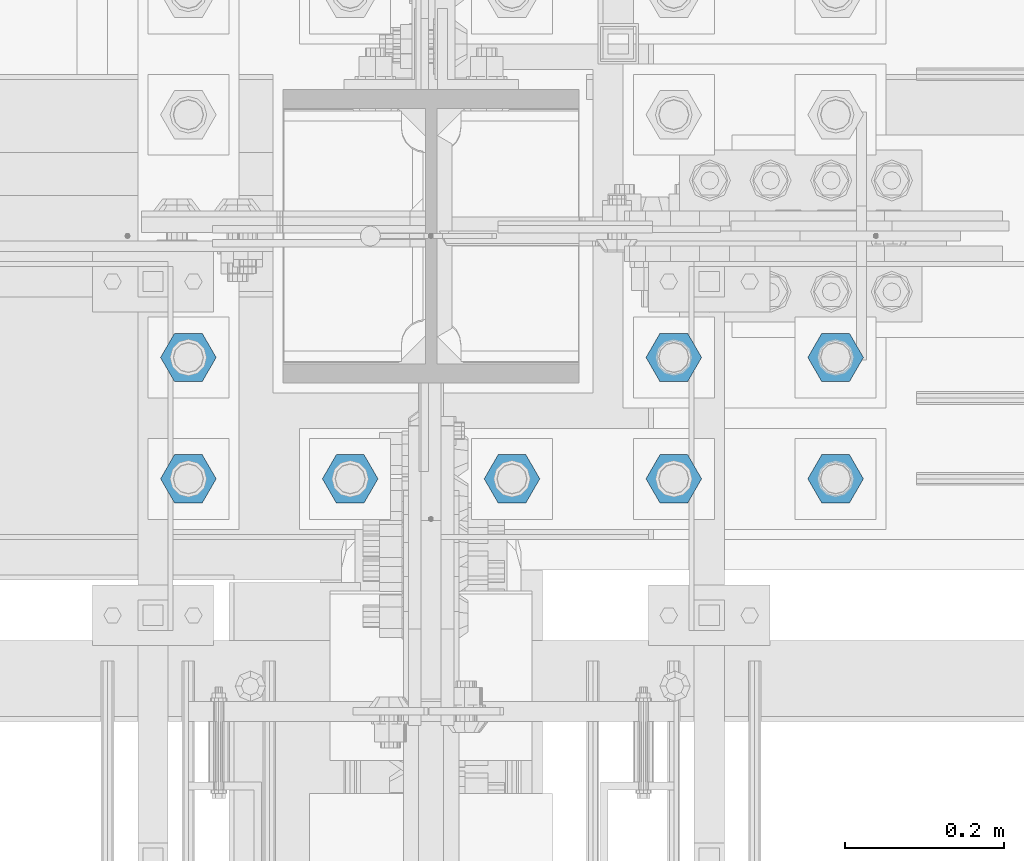
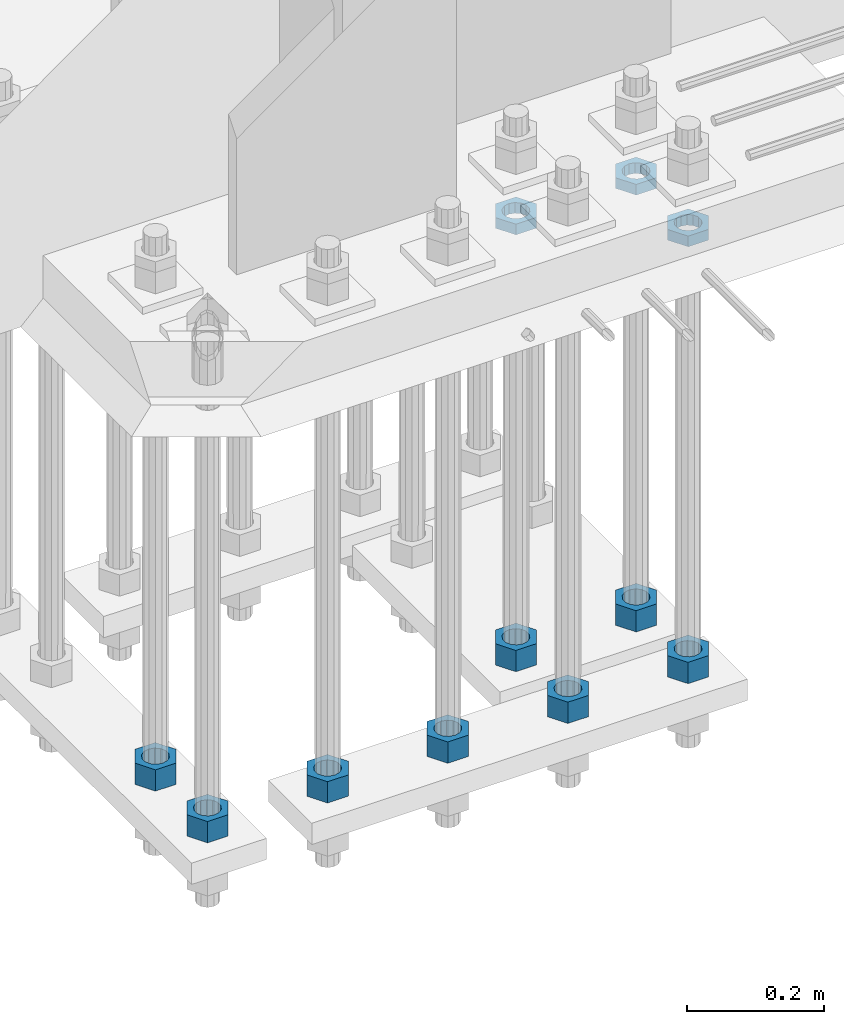
# One storey, part 2822 of 3843: 11 beams, 1 element without a shape of its own.
"""IFC2X3 building model written with IfcOpenShell, lengths in millimetres."""

import ifcopenshell
import ifcopenshell.guid

model = None  # the IFC model being written
_history = None  # IfcOwnerHistory: only IFC2X3 demands one
_inside = {}  # id of a spatial element -> (the spatial element, [elements in it])
_under = {}  # id of a project, library or spatial element -> (it, [spatial elements below it])
_declared = {}  # id of a project -> (the project, [libraries it declares])
_typed = {}  # id of a type object -> (the type object, [elements of that type])
_made_of = {}  # id of a material, layer set ... -> (it, [elements and type objects made of it])


def new_model(schema):
    """Start an empty IFC model of exactly this schema.

    Asked for "IFC4X3", IfcOpenShell would pick the latest addendum, in which some entities
    have other attributes; the version numbers below select the first issue.
    IFC2X3 requires an IfcOwnerHistory on every rooted entity: one is made here for all.
    """
    global model, _history
    if schema == "IFC4X3":
        model = ifcopenshell.file(schema_version=(4, 3, 0, 0))
    else:
        model = ifcopenshell.file(schema=schema)
    _inside.clear()
    _under.clear()
    _declared.clear()
    _typed.clear()
    _made_of.clear()
    _history = None
    if model.schema == "IFC2X3":
        org = make("IfcOrganization", Name="unknown")
        user = make(
            "IfcPersonAndOrganization",
            ThePerson=make("IfcPerson", FamilyName="unknown"),
            TheOrganization=org,
        )
        app = make(
            "IfcApplication",
            ApplicationDeveloper=org,
            Version="unknown",
            ApplicationFullName="unknown",
            ApplicationIdentifier="unknown",
        )
        _history = make(
            "IfcOwnerHistory",
            OwningUser=user,
            OwningApplication=app,
            ChangeAction="ADDED",
            CreationDate=0,
        )
    return model


def make(cls, **values):
    """One entity of the class cls with the attributes given. An attribute that is None is left unset."""
    return model.create_entity(
        cls, **{name: value for name, value in values.items() if value is not None}
    )


def rooted(cls, **values):
    """An entity with a GlobalId (a new one), such as an element, a storey or a relation."""
    return make(cls, GlobalId=ifcopenshell.guid.new(), OwnerHistory=_history, **values)


def si_unit(unit_type, name, prefix=None):
    """IfcSIUnit, for example si_unit("LENGTHUNIT", "METRE", prefix="MILLI")."""
    return make("IfcSIUnit", UnitType=unit_type, Prefix=prefix, Name=name)


def assignment(units):
    """IfcUnitAssignment: the units of a project."""
    return None if units is None else make("IfcUnitAssignment", Units=units)


def point(xyz):
    """IfcCartesianPoint."""
    return None if xyz is None else make("IfcCartesianPoint", Coordinates=xyz)


def direction(xyz):
    """IfcDirection."""
    return None if xyz is None else make("IfcDirection", DirectionRatios=xyz)


def frame(location, z_axis=None, x_axis=None):
    """IfcAxis2Placement3D, a coordinate frame: its origin and axes. An axis left out is left unset."""
    return make(
        "IfcAxis2Placement3D",
        Location=point(location),
        Axis=direction(z_axis),
        RefDirection=direction(x_axis),
    )


def origin_with_axes():
    """The frame at (0, 0, 0) with the z axis (0, 0, 1) and the x axis (1, 0, 0) written out."""
    return frame((0.0, 0.0, 0.0), z_axis=(0.0, 0.0, 1.0), x_axis=(1.0, 0.0, 0.0))


def place(relative_to, where):
    """IfcLocalPlacement: puts the frame where relative to a parent placement (None: the world)."""
    return make(
        "IfcLocalPlacement", PlacementRelTo=relative_to, RelativePlacement=where
    )


def context(
    kind, dimensions, precision=None, world=None, true_north=None, identifier=None
):
    """IfcGeometricRepresentationContext, for example the 3D "Model" context."""
    return make(
        "IfcGeometricRepresentationContext",
        ContextIdentifier=identifier,
        ContextType=kind,
        CoordinateSpaceDimension=dimensions,
        Precision=precision,
        WorldCoordinateSystem=world,
        TrueNorth=true_north,
    )


def subcontext(parent, identifier, kind, view, scale=None):
    """IfcGeometricRepresentationSubContext, for example "Body" below "Model"."""
    return make(
        "IfcGeometricRepresentationSubContext",
        ContextIdentifier=identifier,
        ContextType=kind,
        ParentContext=parent,
        TargetScale=scale,
        TargetView=view,
    )


def project(units=None, contexts=None):
    """IfcProject with its units and contexts."""
    return rooted(
        "IfcProject",
        Name="project",
        RepresentationContexts=contexts,
        UnitsInContext=assignment(units),
    )


def spatial(cls, under=None, at=None, **own):
    """A site, building, storey or space (cls), placed at a placement, below another one or the project."""
    s = rooted(cls, ObjectPlacement=at, **own)
    if under is not None:
        _under.setdefault(under.id(), (under, []))[1].append(s)
    return s


def faces_of(points, faces, orient=None, outer=None):
    """IfcFace entities. A face is a list of loops; a loop is a list of indices into points, from 0.

    orient and outer hold one flag for each loop. By default every Orientation is true, the
    first loop of a face is its IfcFaceOuterBound and the others are IfcFaceBound.
    """
    made = []
    for i, loops in enumerate(faces):
        bounds = []
        for j, loop in enumerate(loops):
            is_outer = j == 0 if outer is None else outer[i][j]
            bounds.append(
                make(
                    "IfcFaceOuterBound" if is_outer else "IfcFaceBound",
                    Bound=make("IfcPolyLoop", Polygon=[points[k] for k in loop]),
                    Orientation=True if orient is None else orient[i][j],
                )
            )
        made.append(make("IfcFace", Bounds=bounds))
    return made


def faceted_brep(points, faces, orient=None, outer=None, voids=None):
    """IfcFacetedBrep: a solid bounded by flat faces; with voids (closed shells), ...WithVoids."""
    shared = [point(p) for p in points]
    hull = make("IfcClosedShell", CfsFaces=faces_of(shared, faces, orient, outer))
    if voids is None:
        return make("IfcFacetedBrep", Outer=hull)
    return make(
        "IfcFacetedBrepWithVoids",
        Outer=hull,
        Voids=[
            make(cls, CfsFaces=faces_of(shared, fs, o, b)) for cls, fs, o, b in voids
        ],
    )


def shape(context_of_items, identifier, shape_type, items):
    """IfcShapeRepresentation: the items that make up one representation, for example the "Body"."""
    return make(
        "IfcShapeRepresentation",
        ContextOfItems=context_of_items,
        RepresentationIdentifier=identifier,
        RepresentationType=shape_type,
        Items=items,
    )


def material(Name=None, Category=None):
    """IfcMaterial."""
    return make("IfcMaterial", Name=Name, Category=Category)


def made_of(thing, what):
    """Note that an element or type object is made of a material, layer set ...; save() writes the relation."""
    if what is not None:
        _made_of.setdefault(what.id(), (what, []))[1].append(thing)
    return thing


def type_object(cls, material=None, **own):
    """A type object (cls), such as IfcWallType, which elements share."""
    return made_of(rooted(cls, **own), material)


def element(
    cls,
    number,
    at=None,
    inside=None,
    cuts=None,
    type_object=None,
    material=None,
    context=None,
    identifier="Body",
    shape_type=None,
    held_by="IfcProductDefinitionShape",
    body=None,
    shapes=None,
    **own,
):
    """One element of the class cls, such as IfcWall. Its Tag is "e" and its number.

    at: its placement. inside: the storey or other place that contains it. cuts: it is an
    opening in that element (IfcRelVoidsElement). A single representation is given by context,
    identifier, shape_type and body (its items); several are given by shapes. held_by: the class
    of the entity that holds the representations. save() writes the other relations.
    """
    e = rooted(cls, Tag="e%d" % number, ObjectPlacement=at, **own)
    if body is not None:
        shapes = [shape(context, identifier, shape_type, body)]
    if shapes is not None:
        e.Representation = make(held_by, Representations=shapes)
    if inside is not None:
        _inside.setdefault(inside.id(), (inside, []))[1].append(e)
    if cuts is not None:
        rooted(
            "IfcRelVoidsElement", RelatingBuildingElement=cuts, RelatedOpeningElement=e
        )
    if type_object is not None:
        _typed.setdefault(type_object.id(), (type_object, []))[1].append(e)
    return made_of(e, material)


def aggregate(whole, parts):
    """IfcRelAggregates: a whole, such as a stair, and the parts it consists of."""
    return rooted("IfcRelAggregates", RelatingObject=whole, RelatedObjects=parts)


def save(model, path):
    """Write the relations noted so far, then the file.

    IfcRelAggregates (storeys below a building ...), IfcRelContainedInSpatialStructure (elements
    in a storey), IfcRelDefinesByType, IfcRelAssociatesMaterial and IfcRelDeclares: one each for
    every whole, place, type object, material and project.
    """
    for whole, parts in _under.values():
        aggregate(whole, parts)
    for where, things in _inside.values():
        rooted(
            "IfcRelContainedInSpatialStructure",
            RelatedElements=things,
            RelatingStructure=where,
        )
    for kind, things in _typed.values():
        rooted("IfcRelDefinesByType", RelatedObjects=things, RelatingType=kind)
    for what, things in _made_of.values():
        rooted("IfcRelAssociatesMaterial", RelatedObjects=things, RelatingMaterial=what)
    for by, libraries in _declared.values():
        rooted("IfcRelDeclares", RelatingContext=by, RelatedDefinitions=libraries)
    model.write(path)


model = new_model("IFC2X3")

# Units and contexts
model_context = context("Model", 3, precision=1e-05, world=origin_with_axes())
body_context = subcontext(model_context, "Body", "Model", "MODEL_VIEW")
ifc_project = project(units=[si_unit("LENGTHUNIT", "METRE", prefix="MILLI"), si_unit("AREAUNIT", "SQUARE_METRE"), si_unit("VOLUMEUNIT", "CUBIC_METRE"), si_unit("MASSUNIT", "GRAM", prefix="KILO"), si_unit("TIMEUNIT", "SECOND"), si_unit("PLANEANGLEUNIT", "RADIAN"), si_unit("SOLIDANGLEUNIT", "STERADIAN"), si_unit("THERMODYNAMICTEMPERATUREUNIT", "DEGREE_CELSIUS"), si_unit("LUMINOUSINTENSITYUNIT", "LUMEN")], contexts=[model_context])

# Site, building, storey
site_placement = place(None, origin_with_axes())
site = spatial("IfcSite", under=ifc_project, at=site_placement, CompositionType="ELEMENT")
building_placement = place(site_placement, origin_with_axes())
building = spatial("IfcBuilding", under=site, at=building_placement, Name="Undefined", CompositionType="ELEMENT")
storey_placement = place(building_placement, origin_with_axes())
storey = spatial("IfcBuildingStorey", under=building, at=storey_placement, Name="Undefined", CompositionType="ELEMENT", Elevation=0.0)

# Assembly, beams
assembly_placement = place(storey_placement, origin_with_axes())
assembly = element("IfcElementAssembly", 1, at=assembly_placement, inside=storey, Name="TEMPLATE", AssemblyPlace="NOTDEFINED", PredefinedType="RIGID_FRAME")
ifc_material = material(Name="STEEL/A572-50")
beam_type_1 = type_object("IfcBeamType", Name="1-1/2_HEAVY_HEX_NUT", PredefinedType="NOTDEFINED")
beam_1_placement = place(assembly_placement, frame((56438.8, 25463.5, 28841.7000015259), z_axis=(0.0, 1.0, 0.0), x_axis=(0.0, 0.0, -1.0)))
beam_1 = element("IfcBeam", 2, at=beam_1_placement, type_object=beam_type_1, material=ifc_material, Name="NUT", ObjectType="1-1/2_HEAVY_HEX_NUT", context=body_context, shape_type="Brep", body=[
    faceted_brep([(0.0, -34.9199981689453, 0.0), (0.0, -17.4599990844727, -30.25), (38.0999999999985, -17.4599990844727, -30.25), (38.0999999999985, -34.9199981689453, 0.0), (0.0, 17.4599990844727, -30.25), (38.0999999999985, 17.4599990844727, -30.25), (0.0, 34.9199981689453, 0.0), (38.0999999999985, 34.9199981689453, 0.0), (0.0, 17.4599990844727, 30.25), (38.0999999999985, 17.4599990844727, 30.25), (0.0, -17.4599990844727, 30.25), (38.0999999999985, -17.4599990844727, 30.25), (0.0, 0.0, 20.6399993896484), (0.0, 8.9553601105581, 18.5959968835959), (38.0999999999985, 8.9553601105581, 18.5959968835959), (38.0999999999985, 0.0, 20.6399993896484), (0.0, 16.1370013209525, 12.8688291298167), (38.0999999999985, 16.1370013209525, 12.8688291298167), (0.0, 20.1225115123816, 4.59283194104501), (38.0999999999985, 20.1225115123816, 4.59283194104501), (0.0, 20.1225115123816, -4.59283194104501), (38.0999999999985, 20.1225115123816, -4.59283194104501), (0.0, 16.1370013209525, -12.8688291298167), (38.0999999999985, 16.1370013209525, -12.8688291298167), (0.0, 8.9553601105581, -18.5959968835959), (38.0999999999985, 8.9553601105581, -18.5959968835959), (0.0, 0.0, -20.6399993896484), (38.0999999999985, 0.0, -20.6399993896484), (0.0, -8.9553601105581, -18.5959968835959), (38.0999999999985, -8.9553601105581, -18.5959968835959), (0.0, -16.1370013209525, -12.8688291298167), (38.0999999999985, -16.1370013209525, -12.8688291298167), (0.0, -20.1225115123816, -4.59283194104501), (38.0999999999985, -20.1225115123816, -4.59283194104501), (0.0, -20.1225115123816, 4.59283194104501), (38.0999999999985, -20.1225115123816, 4.59283194104501), (0.0, -16.1370013209525, 12.8688291298167), (38.0999999999985, -16.1370013209525, 12.8688291298167), (0.0, -8.9553601105581, 18.5959968835959), (38.0999999999985, -8.9553601105581, 18.5959968835959)], [[[0, 1, 2, 3]], [[1, 4, 5, 2]], [[4, 6, 7, 5]], [[6, 8, 9, 7]], [[8, 10, 11, 9]], [[10, 0, 3, 11]], [[12, 13, 14, 15]], [[13, 16, 17, 14]], [[16, 18, 19, 17]], [[18, 20, 21, 19]], [[20, 22, 23, 21]], [[22, 24, 25, 23]], [[24, 26, 27, 25]], [[26, 28, 29, 27]], [[28, 30, 31, 29]], [[30, 32, 33, 31]], [[32, 34, 35, 33]], [[34, 36, 37, 35]], [[36, 38, 39, 37]], [[38, 12, 15, 39]], [[5, 7, 9, 11, 3, 2], [17, 19, 21, 23, 25, 27, 29, 31, 33, 35, 37, 39, 15, 14]], [[10, 8, 6, 4, 1, 0], [38, 36, 34, 32, 30, 28, 26, 24, 22, 20, 18, 16, 13, 12]]]),
])
beam_2_placement = place(assembly_placement, frame((56235.6, 25463.5, 28841.7000015259), z_axis=(0.0, 1.0, 0.0), x_axis=(0.0, 0.0, -1.0)))
beam_2 = element("IfcBeam", 3, at=beam_2_placement, type_object=beam_type_1, material=ifc_material, Name="NUT", ObjectType="1-1/2_HEAVY_HEX_NUT", context=body_context, shape_type="Brep", body=[
    faceted_brep([(0.0, -34.9199981689453, 0.0), (0.0, -17.4599990844727, -30.25), (38.0999999999985, -17.4599990844727, -30.25), (38.0999999999985, -34.9199981689453, 0.0), (0.0, 17.4599990844727, -30.25), (38.0999999999985, 17.4599990844727, -30.25), (0.0, 34.9199981689453, 0.0), (38.0999999999985, 34.9199981689453, 0.0), (0.0, 17.4599990844727, 30.25), (38.0999999999985, 17.4599990844727, 30.25), (0.0, -17.4599990844727, 30.25), (38.0999999999985, -17.4599990844727, 30.25), (0.0, 0.0, 20.6399993896484), (0.0, 8.9553601105581, 18.5959968835959), (38.0999999999985, 8.9553601105581, 18.5959968835959), (38.0999999999985, 0.0, 20.6399993896484), (0.0, 16.1370013209525, 12.8688291298167), (38.0999999999985, 16.1370013209525, 12.8688291298167), (0.0, 20.1225115123816, 4.59283194104501), (38.0999999999985, 20.1225115123816, 4.59283194104501), (0.0, 20.1225115123816, -4.59283194104501), (38.0999999999985, 20.1225115123816, -4.59283194104501), (0.0, 16.1370013209525, -12.8688291298167), (38.0999999999985, 16.1370013209525, -12.8688291298167), (0.0, 8.9553601105581, -18.5959968835959), (38.0999999999985, 8.9553601105581, -18.5959968835959), (0.0, 0.0, -20.6399993896484), (38.0999999999985, 0.0, -20.6399993896484), (0.0, -8.9553601105581, -18.5959968835959), (38.0999999999985, -8.9553601105581, -18.5959968835959), (0.0, -16.1370013209525, -12.8688291298167), (38.0999999999985, -16.1370013209525, -12.8688291298167), (0.0, -20.1225115123816, -4.59283194104501), (38.0999999999985, -20.1225115123816, -4.59283194104501), (0.0, -20.1225115123816, 4.59283194104501), (38.0999999999985, -20.1225115123816, 4.59283194104501), (0.0, -16.1370013209525, 12.8688291298167), (38.0999999999985, -16.1370013209525, 12.8688291298167), (0.0, -8.9553601105581, 18.5959968835959), (38.0999999999985, -8.9553601105581, 18.5959968835959)], [[[0, 1, 2, 3]], [[1, 4, 5, 2]], [[4, 6, 7, 5]], [[6, 8, 9, 7]], [[8, 10, 11, 9]], [[10, 0, 3, 11]], [[12, 13, 14, 15]], [[13, 16, 17, 14]], [[16, 18, 19, 17]], [[18, 20, 21, 19]], [[20, 22, 23, 21]], [[22, 24, 25, 23]], [[24, 26, 27, 25]], [[26, 28, 29, 27]], [[28, 30, 31, 29]], [[30, 32, 33, 31]], [[32, 34, 35, 33]], [[34, 36, 37, 35]], [[36, 38, 39, 37]], [[38, 12, 15, 39]], [[5, 7, 9, 11, 3, 2], [17, 19, 21, 23, 25, 27, 29, 31, 33, 35, 37, 39, 15, 14]], [[10, 8, 6, 4, 1, 0], [38, 36, 34, 32, 30, 28, 26, 24, 22, 20, 18, 16, 13, 12]]]),
])
beam_3_placement = place(assembly_placement, frame((55626.0, 25463.5, 28841.7000015259), z_axis=(0.0, -1.0, 0.0), x_axis=(0.0, 0.0, -1.0)))
beam_3 = element("IfcBeam", 4, at=beam_3_placement, type_object=beam_type_1, material=ifc_material, Name="NUT", ObjectType="1-1/2_HEAVY_HEX_NUT", context=body_context, shape_type="Brep", body=[
    faceted_brep([(0.0, -34.9199981689453, 0.0), (0.0, -17.4599990844727, -30.25), (38.0999999999985, -17.4599990844727, -30.25), (38.0999999999985, -34.9199981689453, 0.0), (0.0, 17.4599990844727, -30.25), (38.0999999999985, 17.4599990844727, -30.25), (0.0, 34.9199981689453, 0.0), (38.0999999999985, 34.9199981689453, 0.0), (0.0, 17.4599990844727, 30.25), (38.0999999999985, 17.4599990844727, 30.25), (0.0, -17.4599990844727, 30.25), (38.0999999999985, -17.4599990844727, 30.25), (0.0, 0.0, 20.6399993896484), (0.0, 8.9553601105581, 18.5959968835959), (38.0999999999985, 8.9553601105581, 18.5959968835959), (38.0999999999985, 0.0, 20.6399993896484), (0.0, 16.1370013209525, 12.8688291298167), (38.0999999999985, 16.1370013209525, 12.8688291298167), (0.0, 20.1225115123816, 4.59283194104501), (38.0999999999985, 20.1225115123816, 4.59283194104501), (0.0, 20.1225115123816, -4.59283194104501), (38.0999999999985, 20.1225115123816, -4.59283194104501), (0.0, 16.1370013209525, -12.8688291298167), (38.0999999999985, 16.1370013209525, -12.8688291298167), (0.0, 8.9553601105581, -18.5959968835959), (38.0999999999985, 8.9553601105581, -18.5959968835959), (0.0, 0.0, -20.6399993896484), (38.0999999999985, 0.0, -20.6399993896484), (0.0, -8.9553601105581, -18.5959968835959), (38.0999999999985, -8.9553601105581, -18.5959968835959), (0.0, -16.1370013209525, -12.8688291298167), (38.0999999999985, -16.1370013209525, -12.8688291298167), (0.0, -20.1225115123816, -4.59283194104501), (38.0999999999985, -20.1225115123816, -4.59283194104501), (0.0, -20.1225115123816, 4.59283194104501), (38.0999999999985, -20.1225115123816, 4.59283194104501), (0.0, -16.1370013209525, 12.8688291298167), (38.0999999999985, -16.1370013209525, 12.8688291298167), (0.0, -8.9553601105581, 18.5959968835959), (38.0999999999985, -8.9553601105581, 18.5959968835959)], [[[0, 1, 2, 3]], [[1, 4, 5, 2]], [[4, 6, 7, 5]], [[6, 8, 9, 7]], [[8, 10, 11, 9]], [[10, 0, 3, 11]], [[12, 13, 14, 15]], [[13, 16, 17, 14]], [[16, 18, 19, 17]], [[18, 20, 21, 19]], [[20, 22, 23, 21]], [[22, 24, 25, 23]], [[24, 26, 27, 25]], [[26, 28, 29, 27]], [[28, 30, 31, 29]], [[30, 32, 33, 31]], [[32, 34, 35, 33]], [[34, 36, 37, 35]], [[36, 38, 39, 37]], [[38, 12, 15, 39]], [[5, 7, 9, 11, 3, 2], [17, 19, 21, 23, 25, 27, 29, 31, 33, 35, 37, 39, 15, 14]], [[10, 8, 6, 4, 1, 0], [38, 36, 34, 32, 30, 28, 26, 24, 22, 20, 18, 16, 13, 12]]]),
])
beam_4_placement = place(assembly_placement, frame((55626.0, 25311.1, 28841.7000015259), z_axis=(0.0, -1.0, 0.0), x_axis=(0.0, 0.0, -1.0)))
beam_4 = element("IfcBeam", 5, at=beam_4_placement, type_object=beam_type_1, material=ifc_material, Name="NUT", ObjectType="1-1/2_HEAVY_HEX_NUT", context=body_context, shape_type="Brep", body=[
    faceted_brep([(0.0, -34.9199981689453, 0.0), (0.0, -17.4599990844727, -30.25), (38.0999999999985, -17.4599990844727, -30.25), (38.0999999999985, -34.9199981689453, 0.0), (0.0, 17.4599990844727, -30.25), (38.0999999999985, 17.4599990844727, -30.25), (0.0, 34.9199981689453, 0.0), (38.0999999999985, 34.9199981689453, 0.0), (0.0, 17.4599990844727, 30.25), (38.0999999999985, 17.4599990844727, 30.25), (0.0, -17.4599990844727, 30.25), (38.0999999999985, -17.4599990844727, 30.25), (0.0, 0.0, 20.6399993896484), (0.0, 8.9553601105581, 18.5959968835959), (38.0999999999985, 8.9553601105581, 18.5959968835959), (38.0999999999985, 0.0, 20.6399993896484), (0.0, 16.1370013209525, 12.8688291298167), (38.0999999999985, 16.1370013209525, 12.8688291298167), (0.0, 20.1225115123816, 4.59283194104501), (38.0999999999985, 20.1225115123816, 4.59283194104501), (0.0, 20.1225115123816, -4.59283194104501), (38.0999999999985, 20.1225115123816, -4.59283194104501), (0.0, 16.1370013209525, -12.8688291298167), (38.0999999999985, 16.1370013209525, -12.8688291298167), (0.0, 8.9553601105581, -18.5959968835959), (38.0999999999985, 8.9553601105581, -18.5959968835959), (0.0, 0.0, -20.6399993896484), (38.0999999999985, 0.0, -20.6399993896484), (0.0, -8.9553601105581, -18.5959968835959), (38.0999999999985, -8.9553601105581, -18.5959968835959), (0.0, -16.1370013209525, -12.8688291298167), (38.0999999999985, -16.1370013209525, -12.8688291298167), (0.0, -20.1225115123816, -4.59283194104501), (38.0999999999985, -20.1225115123816, -4.59283194104501), (0.0, -20.1225115123816, 4.59283194104501), (38.0999999999985, -20.1225115123816, 4.59283194104501), (0.0, -16.1370013209525, 12.8688291298167), (38.0999999999985, -16.1370013209525, 12.8688291298167), (0.0, -8.9553601105581, 18.5959968835959), (38.0999999999985, -8.9553601105581, 18.5959968835959)], [[[0, 1, 2, 3]], [[1, 4, 5, 2]], [[4, 6, 7, 5]], [[6, 8, 9, 7]], [[8, 10, 11, 9]], [[10, 0, 3, 11]], [[12, 13, 14, 15]], [[13, 16, 17, 14]], [[16, 18, 19, 17]], [[18, 20, 21, 19]], [[20, 22, 23, 21]], [[22, 24, 25, 23]], [[24, 26, 27, 25]], [[26, 28, 29, 27]], [[28, 30, 31, 29]], [[30, 32, 33, 31]], [[32, 34, 35, 33]], [[34, 36, 37, 35]], [[36, 38, 39, 37]], [[38, 12, 15, 39]], [[5, 7, 9, 11, 3, 2], [17, 19, 21, 23, 25, 27, 29, 31, 33, 35, 37, 39, 15, 14]], [[10, 8, 6, 4, 1, 0], [38, 36, 34, 32, 30, 28, 26, 24, 22, 20, 18, 16, 13, 12]]]),
])
beam_5_placement = place(assembly_placement, frame((55829.2, 25311.1, 28841.7000015259), z_axis=(0.0, -1.0, 0.0), x_axis=(0.0, 0.0, -1.0)))
beam_5 = element("IfcBeam", 6, at=beam_5_placement, type_object=beam_type_1, material=ifc_material, Name="NUT", ObjectType="1-1/2_HEAVY_HEX_NUT", context=body_context, shape_type="Brep", body=[
    faceted_brep([(0.0, -34.9199981689453, 0.0), (0.0, -17.4599990844727, -30.25), (38.0999999999985, -17.4599990844727, -30.25), (38.0999999999985, -34.9199981689453, 0.0), (0.0, 17.4599990844727, -30.25), (38.0999999999985, 17.4599990844727, -30.25), (0.0, 34.9199981689453, 0.0), (38.0999999999985, 34.9199981689453, 0.0), (0.0, 17.4599990844727, 30.25), (38.0999999999985, 17.4599990844727, 30.25), (0.0, -17.4599990844727, 30.25), (38.0999999999985, -17.4599990844727, 30.25), (0.0, 0.0, 20.6399993896484), (0.0, 8.9553601105581, 18.5959968835959), (38.0999999999985, 8.9553601105581, 18.5959968835959), (38.0999999999985, 0.0, 20.6399993896484), (0.0, 16.1370013209525, 12.8688291298167), (38.0999999999985, 16.1370013209525, 12.8688291298167), (0.0, 20.1225115123816, 4.59283194104501), (38.0999999999985, 20.1225115123816, 4.59283194104501), (0.0, 20.1225115123816, -4.59283194104501), (38.0999999999985, 20.1225115123816, -4.59283194104501), (0.0, 16.1370013209525, -12.8688291298167), (38.0999999999985, 16.1370013209525, -12.8688291298167), (0.0, 8.9553601105581, -18.5959968835959), (38.0999999999985, 8.9553601105581, -18.5959968835959), (0.0, 0.0, -20.6399993896484), (38.0999999999985, 0.0, -20.6399993896484), (0.0, -8.9553601105581, -18.5959968835959), (38.0999999999985, -8.9553601105581, -18.5959968835959), (0.0, -16.1370013209525, -12.8688291298167), (38.0999999999985, -16.1370013209525, -12.8688291298167), (0.0, -20.1225115123816, -4.59283194104501), (38.0999999999985, -20.1225115123816, -4.59283194104501), (0.0, -20.1225115123816, 4.59283194104501), (38.0999999999985, -20.1225115123816, 4.59283194104501), (0.0, -16.1370013209525, 12.8688291298167), (38.0999999999985, -16.1370013209525, 12.8688291298167), (0.0, -8.9553601105581, 18.5959968835959), (38.0999999999985, -8.9553601105581, 18.5959968835959)], [[[0, 1, 2, 3]], [[1, 4, 5, 2]], [[4, 6, 7, 5]], [[6, 8, 9, 7]], [[8, 10, 11, 9]], [[10, 0, 3, 11]], [[12, 13, 14, 15]], [[13, 16, 17, 14]], [[16, 18, 19, 17]], [[18, 20, 21, 19]], [[20, 22, 23, 21]], [[22, 24, 25, 23]], [[24, 26, 27, 25]], [[26, 28, 29, 27]], [[28, 30, 31, 29]], [[30, 32, 33, 31]], [[32, 34, 35, 33]], [[34, 36, 37, 35]], [[36, 38, 39, 37]], [[38, 12, 15, 39]], [[5, 7, 9, 11, 3, 2], [17, 19, 21, 23, 25, 27, 29, 31, 33, 35, 37, 39, 15, 14]], [[10, 8, 6, 4, 1, 0], [38, 36, 34, 32, 30, 28, 26, 24, 22, 20, 18, 16, 13, 12]]]),
])
beam_6_placement = place(assembly_placement, frame((56032.4, 25311.1, 28841.7000015259), z_axis=(0.0, -1.0, 0.0), x_axis=(0.0, 0.0, -1.0)))
beam_6 = element("IfcBeam", 7, at=beam_6_placement, type_object=beam_type_1, material=ifc_material, Name="NUT", ObjectType="1-1/2_HEAVY_HEX_NUT", context=body_context, shape_type="Brep", body=[
    faceted_brep([(0.0, -34.9199981689453, 0.0), (0.0, -17.4599990844727, -30.25), (38.0999999999985, -17.4599990844727, -30.25), (38.0999999999985, -34.9199981689453, 0.0), (0.0, 17.4599990844727, -30.25), (38.0999999999985, 17.4599990844727, -30.25), (0.0, 34.9199981689453, 0.0), (38.0999999999985, 34.9199981689453, 0.0), (0.0, 17.4599990844727, 30.25), (38.0999999999985, 17.4599990844727, 30.25), (0.0, -17.4599990844727, 30.25), (38.0999999999985, -17.4599990844727, 30.25), (0.0, 0.0, 20.6399993896484), (0.0, 8.9553601105581, 18.5959968835959), (38.0999999999985, 8.9553601105581, 18.5959968835959), (38.0999999999985, 0.0, 20.6399993896484), (0.0, 16.1370013209525, 12.8688291298167), (38.0999999999985, 16.1370013209525, 12.8688291298167), (0.0, 20.1225115123816, 4.59283194104501), (38.0999999999985, 20.1225115123816, 4.59283194104501), (0.0, 20.1225115123816, -4.59283194104501), (38.0999999999985, 20.1225115123816, -4.59283194104501), (0.0, 16.1370013209525, -12.8688291298167), (38.0999999999985, 16.1370013209525, -12.8688291298167), (0.0, 8.9553601105581, -18.5959968835959), (38.0999999999985, 8.9553601105581, -18.5959968835959), (0.0, 0.0, -20.6399993896484), (38.0999999999985, 0.0, -20.6399993896484), (0.0, -8.9553601105581, -18.5959968835959), (38.0999999999985, -8.9553601105581, -18.5959968835959), (0.0, -16.1370013209525, -12.8688291298167), (38.0999999999985, -16.1370013209525, -12.8688291298167), (0.0, -20.1225115123816, -4.59283194104501), (38.0999999999985, -20.1225115123816, -4.59283194104501), (0.0, -20.1225115123816, 4.59283194104501), (38.0999999999985, -20.1225115123816, 4.59283194104501), (0.0, -16.1370013209525, 12.8688291298167), (38.0999999999985, -16.1370013209525, 12.8688291298167), (0.0, -8.9553601105581, 18.5959968835959), (38.0999999999985, -8.9553601105581, 18.5959968835959)], [[[0, 1, 2, 3]], [[1, 4, 5, 2]], [[4, 6, 7, 5]], [[6, 8, 9, 7]], [[8, 10, 11, 9]], [[10, 0, 3, 11]], [[12, 13, 14, 15]], [[13, 16, 17, 14]], [[16, 18, 19, 17]], [[18, 20, 21, 19]], [[20, 22, 23, 21]], [[22, 24, 25, 23]], [[24, 26, 27, 25]], [[26, 28, 29, 27]], [[28, 30, 31, 29]], [[30, 32, 33, 31]], [[32, 34, 35, 33]], [[34, 36, 37, 35]], [[36, 38, 39, 37]], [[38, 12, 15, 39]], [[5, 7, 9, 11, 3, 2], [17, 19, 21, 23, 25, 27, 29, 31, 33, 35, 37, 39, 15, 14]], [[10, 8, 6, 4, 1, 0], [38, 36, 34, 32, 30, 28, 26, 24, 22, 20, 18, 16, 13, 12]]]),
])
beam_7_placement = place(assembly_placement, frame((56235.6, 25311.1, 28841.7000015259), z_axis=(0.0, 1.0, 0.0), x_axis=(0.0, 0.0, -1.0)))
beam_7 = element("IfcBeam", 8, at=beam_7_placement, type_object=beam_type_1, material=ifc_material, Name="NUT", ObjectType="1-1/2_HEAVY_HEX_NUT", context=body_context, shape_type="Brep", body=[
    faceted_brep([(0.0, -34.9199981689453, 0.0), (0.0, -17.4599990844727, -30.25), (38.0999999999985, -17.4599990844727, -30.25), (38.0999999999985, -34.9199981689453, 0.0), (0.0, 17.4599990844727, -30.25), (38.0999999999985, 17.4599990844727, -30.25), (0.0, 34.9199981689453, 0.0), (38.0999999999985, 34.9199981689453, 0.0), (0.0, 17.4599990844727, 30.25), (38.0999999999985, 17.4599990844727, 30.25), (0.0, -17.4599990844727, 30.25), (38.0999999999985, -17.4599990844727, 30.25), (0.0, 0.0, 20.6399993896484), (0.0, 8.9553601105581, 18.5959968835959), (38.0999999999985, 8.9553601105581, 18.5959968835959), (38.0999999999985, 0.0, 20.6399993896484), (0.0, 16.1370013209525, 12.8688291298167), (38.0999999999985, 16.1370013209525, 12.8688291298167), (0.0, 20.1225115123816, 4.59283194104501), (38.0999999999985, 20.1225115123816, 4.59283194104501), (0.0, 20.1225115123816, -4.59283194104501), (38.0999999999985, 20.1225115123816, -4.59283194104501), (0.0, 16.1370013209525, -12.8688291298167), (38.0999999999985, 16.1370013209525, -12.8688291298167), (0.0, 8.9553601105581, -18.5959968835959), (38.0999999999985, 8.9553601105581, -18.5959968835959), (0.0, 0.0, -20.6399993896484), (38.0999999999985, 0.0, -20.6399993896484), (0.0, -8.9553601105581, -18.5959968835959), (38.0999999999985, -8.9553601105581, -18.5959968835959), (0.0, -16.1370013209525, -12.8688291298167), (38.0999999999985, -16.1370013209525, -12.8688291298167), (0.0, -20.1225115123816, -4.59283194104501), (38.0999999999985, -20.1225115123816, -4.59283194104501), (0.0, -20.1225115123816, 4.59283194104501), (38.0999999999985, -20.1225115123816, 4.59283194104501), (0.0, -16.1370013209525, 12.8688291298167), (38.0999999999985, -16.1370013209525, 12.8688291298167), (0.0, -8.9553601105581, 18.5959968835959), (38.0999999999985, -8.9553601105581, 18.5959968835959)], [[[0, 1, 2, 3]], [[1, 4, 5, 2]], [[4, 6, 7, 5]], [[6, 8, 9, 7]], [[8, 10, 11, 9]], [[10, 0, 3, 11]], [[12, 13, 14, 15]], [[13, 16, 17, 14]], [[16, 18, 19, 17]], [[18, 20, 21, 19]], [[20, 22, 23, 21]], [[22, 24, 25, 23]], [[24, 26, 27, 25]], [[26, 28, 29, 27]], [[28, 30, 31, 29]], [[30, 32, 33, 31]], [[32, 34, 35, 33]], [[34, 36, 37, 35]], [[36, 38, 39, 37]], [[38, 12, 15, 39]], [[5, 7, 9, 11, 3, 2], [17, 19, 21, 23, 25, 27, 29, 31, 33, 35, 37, 39, 15, 14]], [[10, 8, 6, 4, 1, 0], [38, 36, 34, 32, 30, 28, 26, 24, 22, 20, 18, 16, 13, 12]]]),
])
beam_8_placement = place(assembly_placement, frame((56438.8, 25311.1, 28841.7000015259), z_axis=(0.0, 1.0, 0.0), x_axis=(0.0, 0.0, -1.0)))
beam_8 = element("IfcBeam", 9, at=beam_8_placement, type_object=beam_type_1, material=ifc_material, Name="NUT", ObjectType="1-1/2_HEAVY_HEX_NUT", context=body_context, shape_type="Brep", body=[
    faceted_brep([(0.0, -34.9199981689453, 0.0), (0.0, -17.4599990844727, -30.25), (38.0999999999985, -17.4599990844727, -30.25), (38.0999999999985, -34.9199981689453, 0.0), (0.0, 17.4599990844727, -30.25), (38.0999999999985, 17.4599990844727, -30.25), (0.0, 34.9199981689453, 0.0), (38.0999999999985, 34.9199981689453, 0.0), (0.0, 17.4599990844727, 30.25), (38.0999999999985, 17.4599990844727, 30.25), (0.0, -17.4599990844727, 30.25), (38.0999999999985, -17.4599990844727, 30.25), (0.0, 0.0, 20.6399993896484), (0.0, 8.9553601105581, 18.5959968835959), (38.0999999999985, 8.9553601105581, 18.5959968835959), (38.0999999999985, 0.0, 20.6399993896484), (0.0, 16.1370013209525, 12.8688291298167), (38.0999999999985, 16.1370013209525, 12.8688291298167), (0.0, 20.1225115123816, 4.59283194104501), (38.0999999999985, 20.1225115123816, 4.59283194104501), (0.0, 20.1225115123816, -4.59283194104501), (38.0999999999985, 20.1225115123816, -4.59283194104501), (0.0, 16.1370013209525, -12.8688291298167), (38.0999999999985, 16.1370013209525, -12.8688291298167), (0.0, 8.9553601105581, -18.5959968835959), (38.0999999999985, 8.9553601105581, -18.5959968835959), (0.0, 0.0, -20.6399993896484), (38.0999999999985, 0.0, -20.6399993896484), (0.0, -8.9553601105581, -18.5959968835959), (38.0999999999985, -8.9553601105581, -18.5959968835959), (0.0, -16.1370013209525, -12.8688291298167), (38.0999999999985, -16.1370013209525, -12.8688291298167), (0.0, -20.1225115123816, -4.59283194104501), (38.0999999999985, -20.1225115123816, -4.59283194104501), (0.0, -20.1225115123816, 4.59283194104501), (38.0999999999985, -20.1225115123816, 4.59283194104501), (0.0, -16.1370013209525, 12.8688291298167), (38.0999999999985, -16.1370013209525, 12.8688291298167), (0.0, -8.9553601105581, 18.5959968835959), (38.0999999999985, -8.9553601105581, 18.5959968835959)], [[[0, 1, 2, 3]], [[1, 4, 5, 2]], [[4, 6, 7, 5]], [[6, 8, 9, 7]], [[8, 10, 11, 9]], [[10, 0, 3, 11]], [[12, 13, 14, 15]], [[13, 16, 17, 14]], [[16, 18, 19, 17]], [[18, 20, 21, 19]], [[20, 22, 23, 21]], [[22, 24, 25, 23]], [[24, 26, 27, 25]], [[26, 28, 29, 27]], [[28, 30, 31, 29]], [[30, 32, 33, 31]], [[32, 34, 35, 33]], [[34, 36, 37, 35]], [[36, 38, 39, 37]], [[38, 12, 15, 39]], [[5, 7, 9, 11, 3, 2], [17, 19, 21, 23, 25, 27, 29, 31, 33, 35, 37, 39, 15, 14]], [[10, 8, 6, 4, 1, 0], [38, 36, 34, 32, 30, 28, 26, 24, 22, 20, 18, 16, 13, 12]]]),
])
beam_type_2 = type_object("IfcBeamType", Name="1-1/2_HALF_NUT", PredefinedType="NOTDEFINED")
beam_9_placement = place(assembly_placement, frame((56438.8, 25463.5, 29603.7), z_axis=(0.0, 1.0, 0.0), x_axis=(0.0, 0.0, -1.0)))
beam_9 = element("IfcBeam", 10, at=beam_9_placement, type_object=beam_type_2, material=ifc_material, Name="NUT", ObjectType="1-1/2_HALF_NUT", context=body_context, shape_type="Brep", body=[
    faceted_brep([(0.0, -34.9199981689453, 0.0), (0.0, -17.4599990844727, -30.25), (19.0500000000029, -17.4599990844727, -30.25), (19.0500000000029, -34.9199981689453, 0.0), (0.0, 17.4599990844727, -30.25), (19.0500000000029, 17.4599990844727, -30.25), (0.0, 34.9199981689453, 0.0), (19.0500000000029, 34.9199981689453, 0.0), (0.0, 17.4599990844727, 30.25), (19.0500000000029, 17.4599990844727, 30.25), (0.0, -17.4599990844727, 30.25), (19.0500000000029, -17.4599990844727, 30.25), (0.0, 0.0, 20.6399993896484), (0.0, 8.9553601105581, 18.5959968835959), (19.0500000000029, 8.95536011056538, 18.5959968835959), (19.0500000000029, 0.0, 20.6399993896484), (0.0, 16.1370013209525, 12.8688291298167), (19.0500000000029, 16.1370013209489, 12.8688291298167), (0.0, 20.1225115123816, 4.59283194104501), (19.0500000000029, 20.1225115123852, 4.59283194104501), (0.0, 20.1225115123816, -4.59283194104501), (19.0500000000029, 20.1225115123852, -4.59283194104501), (0.0, 16.1370013209525, -12.8688291298167), (19.0500000000029, 16.1370013209489, -12.8688291298167), (0.0, 8.9553601105581, -18.5959968835959), (19.0500000000029, 8.95536011056538, -18.5959968835959), (0.0, 0.0, -20.6399993896484), (19.0500000000029, 0.0, -20.6399993896484), (0.0, -8.9553601105581, -18.5959968835959), (19.0500000000029, -8.95536011056538, -18.5959968835959), (0.0, -16.1370013209525, -12.8688291298167), (19.0500000000029, -16.1370013209489, -12.8688291298167), (0.0, -20.1225115123816, -4.59283194104501), (19.0500000000029, -20.1225115123852, -4.59283194104501), (0.0, -20.1225115123816, 4.59283194104501), (19.0500000000029, -20.1225115123852, 4.59283194104501), (0.0, -16.1370013209525, 12.8688291298167), (19.0500000000029, -16.1370013209489, 12.8688291298167), (0.0, -8.9553601105581, 18.5959968835959), (19.0500000000029, -8.95536011056538, 18.5959968835959)], [[[0, 1, 2, 3]], [[1, 4, 5, 2]], [[4, 6, 7, 5]], [[6, 8, 9, 7]], [[8, 10, 11, 9]], [[10, 0, 3, 11]], [[12, 13, 14, 15]], [[13, 16, 17, 14]], [[16, 18, 19, 17]], [[18, 20, 21, 19]], [[20, 22, 23, 21]], [[22, 24, 25, 23]], [[24, 26, 27, 25]], [[26, 28, 29, 27]], [[28, 30, 31, 29]], [[30, 32, 33, 31]], [[32, 34, 35, 33]], [[34, 36, 37, 35]], [[36, 38, 39, 37]], [[38, 12, 15, 39]], [[5, 7, 9, 11, 3, 2], [17, 19, 21, 23, 25, 27, 29, 31, 33, 35, 37, 39, 15, 14]], [[10, 8, 6, 4, 1, 0], [38, 36, 34, 32, 30, 28, 26, 24, 22, 20, 18, 16, 13, 12]]]),
])
beam_10_placement = place(assembly_placement, frame((56438.8, 25311.1, 29603.7), z_axis=(0.0, 1.0, 0.0), x_axis=(0.0, 0.0, -1.0)))
beam_10 = element("IfcBeam", 11, at=beam_10_placement, type_object=beam_type_2, material=ifc_material, Name="NUT", ObjectType="1-1/2_HALF_NUT", context=body_context, shape_type="Brep", body=[
    faceted_brep([(0.0, -34.9199981689453, 0.0), (0.0, -17.4599990844727, -30.25), (19.0500000000029, -17.4599990844727, -30.25), (19.0500000000029, -34.9199981689453, 0.0), (0.0, 17.4599990844727, -30.25), (19.0500000000029, 17.4599990844727, -30.25), (0.0, 34.9199981689453, 0.0), (19.0500000000029, 34.9199981689453, 0.0), (0.0, 17.4599990844727, 30.25), (19.0500000000029, 17.4599990844727, 30.25), (0.0, -17.4599990844727, 30.25), (19.0500000000029, -17.4599990844727, 30.25), (0.0, 0.0, 20.6399993896484), (0.0, 8.9553601105581, 18.5959968835959), (19.0500000000029, 8.95536011056538, 18.5959968835959), (19.0500000000029, 0.0, 20.6399993896484), (0.0, 16.1370013209525, 12.8688291298167), (19.0500000000029, 16.1370013209489, 12.8688291298167), (0.0, 20.1225115123816, 4.59283194104501), (19.0500000000029, 20.1225115123852, 4.59283194104501), (0.0, 20.1225115123816, -4.59283194104501), (19.0500000000029, 20.1225115123852, -4.59283194104501), (0.0, 16.1370013209525, -12.8688291298167), (19.0500000000029, 16.1370013209489, -12.8688291298167), (0.0, 8.9553601105581, -18.5959968835959), (19.0500000000029, 8.95536011056538, -18.5959968835959), (0.0, 0.0, -20.6399993896484), (19.0500000000029, 0.0, -20.6399993896484), (0.0, -8.9553601105581, -18.5959968835959), (19.0500000000029, -8.95536011056538, -18.5959968835959), (0.0, -16.1370013209525, -12.8688291298167), (19.0500000000029, -16.1370013209489, -12.8688291298167), (0.0, -20.1225115123816, -4.59283194104501), (19.0500000000029, -20.1225115123852, -4.59283194104501), (0.0, -20.1225115123816, 4.59283194104501), (19.0500000000029, -20.1225115123852, 4.59283194104501), (0.0, -16.1370013209525, 12.8688291298167), (19.0500000000029, -16.1370013209489, 12.8688291298167), (0.0, -8.9553601105581, 18.5959968835959), (19.0500000000029, -8.95536011056538, 18.5959968835959)], [[[0, 1, 2, 3]], [[1, 4, 5, 2]], [[4, 6, 7, 5]], [[6, 8, 9, 7]], [[8, 10, 11, 9]], [[10, 0, 3, 11]], [[12, 13, 14, 15]], [[13, 16, 17, 14]], [[16, 18, 19, 17]], [[18, 20, 21, 19]], [[20, 22, 23, 21]], [[22, 24, 25, 23]], [[24, 26, 27, 25]], [[26, 28, 29, 27]], [[28, 30, 31, 29]], [[30, 32, 33, 31]], [[32, 34, 35, 33]], [[34, 36, 37, 35]], [[36, 38, 39, 37]], [[38, 12, 15, 39]], [[5, 7, 9, 11, 3, 2], [17, 19, 21, 23, 25, 27, 29, 31, 33, 35, 37, 39, 15, 14]], [[10, 8, 6, 4, 1, 0], [38, 36, 34, 32, 30, 28, 26, 24, 22, 20, 18, 16, 13, 12]]]),
])
beam_11_placement = place(assembly_placement, frame((56235.6, 25463.5, 29603.7), z_axis=(0.0, 1.0, 0.0), x_axis=(0.0, 0.0, -1.0)))
beam_11 = element("IfcBeam", 12, at=beam_11_placement, type_object=beam_type_2, material=ifc_material, Name="NUT", ObjectType="1-1/2_HALF_NUT", context=body_context, shape_type="Brep", body=[
    faceted_brep([(0.0, -34.9199981689453, 0.0), (0.0, -17.4599990844727, -30.25), (19.0500000000029, -17.4599990844727, -30.25), (19.0500000000029, -34.9199981689453, 0.0), (0.0, 17.4599990844727, -30.25), (19.0500000000029, 17.4599990844727, -30.25), (0.0, 34.9199981689453, 0.0), (19.0500000000029, 34.9199981689453, 0.0), (0.0, 17.4599990844727, 30.25), (19.0500000000029, 17.4599990844727, 30.25), (0.0, -17.4599990844727, 30.25), (19.0500000000029, -17.4599990844727, 30.25), (0.0, 0.0, 20.6399993896484), (0.0, 8.9553601105581, 18.5959968835959), (19.0500000000029, 8.95536011056538, 18.5959968835959), (19.0500000000029, 0.0, 20.6399993896484), (0.0, 16.1370013209525, 12.8688291298167), (19.0500000000029, 16.1370013209489, 12.8688291298167), (0.0, 20.1225115123816, 4.59283194104501), (19.0500000000029, 20.1225115123852, 4.59283194104501), (0.0, 20.1225115123816, -4.59283194104501), (19.0500000000029, 20.1225115123852, -4.59283194104501), (0.0, 16.1370013209525, -12.8688291298167), (19.0500000000029, 16.1370013209489, -12.8688291298167), (0.0, 8.9553601105581, -18.5959968835959), (19.0500000000029, 8.95536011056538, -18.5959968835959), (0.0, 0.0, -20.6399993896484), (19.0500000000029, 0.0, -20.6399993896484), (0.0, -8.9553601105581, -18.5959968835959), (19.0500000000029, -8.95536011056538, -18.5959968835959), (0.0, -16.1370013209525, -12.8688291298167), (19.0500000000029, -16.1370013209489, -12.8688291298167), (0.0, -20.1225115123816, -4.59283194104501), (19.0500000000029, -20.1225115123852, -4.59283194104501), (0.0, -20.1225115123816, 4.59283194104501), (19.0500000000029, -20.1225115123852, 4.59283194104501), (0.0, -16.1370013209525, 12.8688291298167), (19.0500000000029, -16.1370013209489, 12.8688291298167), (0.0, -8.9553601105581, 18.5959968835959), (19.0500000000029, -8.95536011056538, 18.5959968835959)], [[[0, 1, 2, 3]], [[1, 4, 5, 2]], [[4, 6, 7, 5]], [[6, 8, 9, 7]], [[8, 10, 11, 9]], [[10, 0, 3, 11]], [[12, 13, 14, 15]], [[13, 16, 17, 14]], [[16, 18, 19, 17]], [[18, 20, 21, 19]], [[20, 22, 23, 21]], [[22, 24, 25, 23]], [[24, 26, 27, 25]], [[26, 28, 29, 27]], [[28, 30, 31, 29]], [[30, 32, 33, 31]], [[32, 34, 35, 33]], [[34, 36, 37, 35]], [[36, 38, 39, 37]], [[38, 12, 15, 39]], [[5, 7, 9, 11, 3, 2], [17, 19, 21, 23, 25, 27, 29, 31, 33, 35, 37, 39, 15, 14]], [[10, 8, 6, 4, 1, 0], [38, 36, 34, 32, 30, 28, 26, 24, 22, 20, 18, 16, 13, 12]]]),
])
aggregate(assembly, [beam_1, beam_2, beam_3, beam_4, beam_5, beam_6, beam_7, beam_8, beam_9, beam_10, beam_11])

save(model, "model.ifc")
